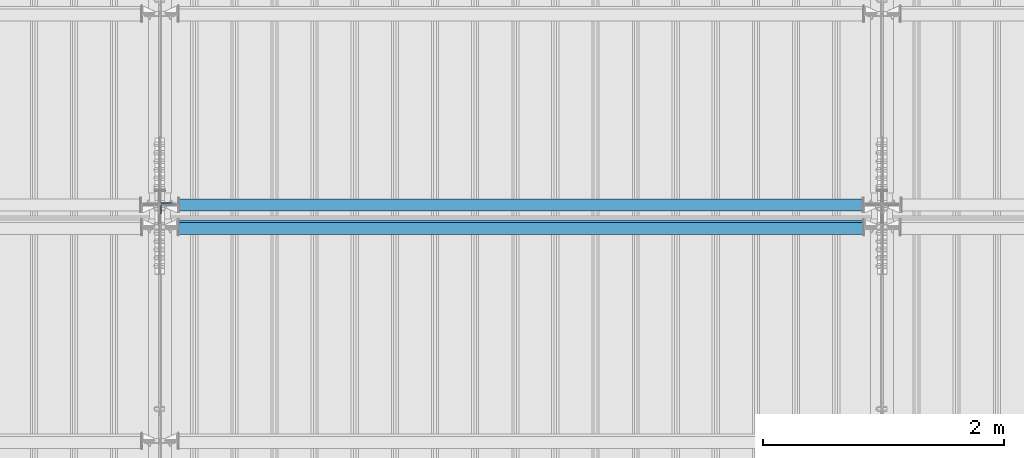
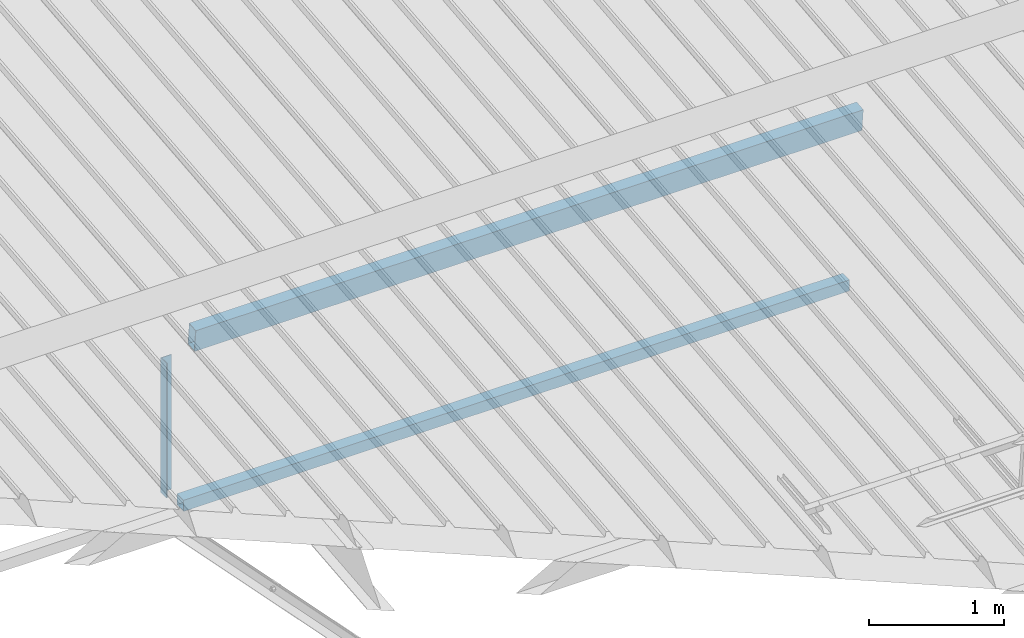
# One storey, part 255 of 709: 3 beams, 3 elements without a shape of their own.
"""IFC4 building model written with IfcOpenShell, lengths in millimetres."""

from ifc_helpers import new_model, si_unit, direction, frame, origin_with_axes, place, context, subcontext, project, spatial, polygons, material, element, aggregate, save


model = new_model("IFC4")

# Units and contexts
model_context = context("Model", 3, precision=0.2, world=origin_with_axes(), true_north=direction((0.0, 1.0)))
body_context = subcontext(model_context, "Body", "Model", "MODEL_VIEW")
ifc_project = project(units=[si_unit("LENGTHUNIT", "METRE", prefix="MILLI"), si_unit("AREAUNIT", "SQUARE_METRE"), si_unit("VOLUMEUNIT", "CUBIC_METRE"), si_unit("MASSUNIT", "GRAM", prefix="KILO"), si_unit("TIMEUNIT", "SECOND"), si_unit("PLANEANGLEUNIT", "RADIAN"), si_unit("SOLIDANGLEUNIT", "STERADIAN"), si_unit("THERMODYNAMICTEMPERATUREUNIT", "DEGREE_CELSIUS"), si_unit("LUMINOUSINTENSITYUNIT", "LUMEN")], contexts=[model_context])

# Site, building, storey
site_placement = place(None, origin_with_axes())
site = spatial("IfcSite", under=ifc_project, at=site_placement, CompositionType="ELEMENT")
building_placement = place(site_placement, origin_with_axes())
building = spatial("IfcBuilding", under=site, at=building_placement, Name="Undefined", CompositionType="ELEMENT")
storey_placement = place(building_placement, origin_with_axes())
storey = spatial("IfcBuildingStorey", under=building, at=storey_placement, Name="Undefined", CompositionType="ELEMENT", Elevation=0.0)

# Assembly, beam
assembly_1_placement = place(storey_placement, frame((28051.0, 5648.7, 7622.40002), z_axis=(0.0, -1.0, 0.0), x_axis=(0.0, 0.0, -1.0)))
assembly_1 = element("IfcElementAssembly", 1, at=assembly_1_placement, inside=storey)
ifc_material_1 = material(Name="C345-5", Category="STEEL")
beam_1_placement = place(assembly_1_placement, origin_with_axes())
beam_1 = element("IfcBeam", 2, at=beam_1_placement, material=ifc_material_1, ObjectType="436", context=body_context, shape_type="Tessellation", body=[
    polygons([(199.0491, -45.0, -45.0), (199.0491, 45.0, -45.0), (1412.4, 45.0, -45.0), (1412.4, -45.0, -45.0), (199.0491, 45.0, -39.0), (1412.4, 45.0, -39.0), (199.0491, -39.0, -39.0), (1412.4, -39.0, -39.0), (199.0491, -39.0, 45.0), (1412.4, -39.0, 45.0), (199.0491, -45.0, 45.0), (1412.4, -45.0, 45.0)], [[[1, 2, 3, 4]], [[2, 5, 6, 3]], [[5, 7, 8, 6]], [[7, 9, 10, 8]], [[9, 11, 12, 10]], [[11, 1, 4, 12]], [[6, 8, 10, 12, 4, 3]], [[11, 9, 7, 5, 2, 1]]], closed=True),
])
aggregate(assembly_1, [beam_1])

assembly_2_placement = place(storey_placement, frame((28000.0, 5673.0, 6074.30002), z_axis=(0.0, -1.0, 0.0), x_axis=(1.0, 0.0, 0.0)))
assembly_2 = element("IfcElementAssembly", 3, at=assembly_2_placement, inside=storey)
ifc_material_2 = material(Name="C355", Category="STEEL")
beam_2_placement = place(assembly_2_placement, origin_with_axes())
beam_2 = element("IfcBeam", 4, at=beam_2_placement, material=ifc_material_2, ObjectType="557", context=body_context, shape_type="Tessellation", body=[
    polygons([(162.0, -47.0, -47.0), (162.0, -47.0, 47.0), (5838.0, -47.0, 47.0), (5838.0, -47.0, -47.0), (162.0, 47.0, 47.0), (5838.0, 47.0, 47.0), (162.0, 47.0, -47.0), (5838.0, 47.0, -47.0), (162.0, -50.0, -50.0), (162.0, 50.0, -50.0), (5838.0, 50.0, -50.0), (5838.0, -50.0, -50.0), (162.0, 50.0, 50.0), (5838.0, 50.0, 50.0), (162.0, -50.0, 50.0), (5838.0, -50.0, 50.0)], [[[1, 2, 3, 4]], [[2, 5, 6, 3]], [[5, 7, 8, 6]], [[7, 1, 4, 8]], [[9, 10, 11, 12]], [[10, 13, 14, 11]], [[13, 15, 16, 14]], [[15, 9, 12, 16]], [[14, 16, 12, 11], [6, 8, 4, 3]], [[15, 13, 10, 9], [7, 5, 2, 1]]], closed=True),
])
aggregate(assembly_2, [beam_2])

assembly_3_placement = place(storey_placement, frame((28000.0, 5490.04963, 7677.46908), z_axis=(0.0, 0.9950371902, 0.099503719), x_axis=(1.0, 0.0, 0.0)))
assembly_3 = element("IfcElementAssembly", 5, at=assembly_3_placement, inside=storey)
beam_3_placement = place(assembly_3_placement, origin_with_axes())
beam_3 = element("IfcBeam", 6, at=beam_3_placement, material=ifc_material_2, ObjectType="579", context=body_context, shape_type="Tessellation", body=[
    polygons([(155.0, -96.0, -46.0), (155.0, -96.0, 46.0), (5845.0, -96.0, 46.0), (5845.0, -96.0, -46.0), (155.0, 96.0, 46.0), (5845.0, 96.0, 46.0), (155.0, 96.0, -46.0), (5845.0, 96.0, -46.0), (155.0, -100.0, -50.0), (155.0, 100.0, -50.0), (5845.0, 100.0, -50.0), (5845.0, -100.0, -50.0), (155.0, 100.0, 50.0), (5845.0, 100.0, 50.0), (155.0, -100.0, 50.0), (5845.0, -100.0, 50.0)], [[[1, 2, 3, 4]], [[2, 5, 6, 3]], [[5, 7, 8, 6]], [[7, 1, 4, 8]], [[9, 10, 11, 12]], [[10, 13, 14, 11]], [[13, 15, 16, 14]], [[15, 9, 12, 16]], [[14, 16, 12, 11], [6, 8, 4, 3]], [[15, 13, 10, 9], [7, 5, 2, 1]]], closed=True),
])
aggregate(assembly_3, [beam_3])

save(model, "model.ifc")
